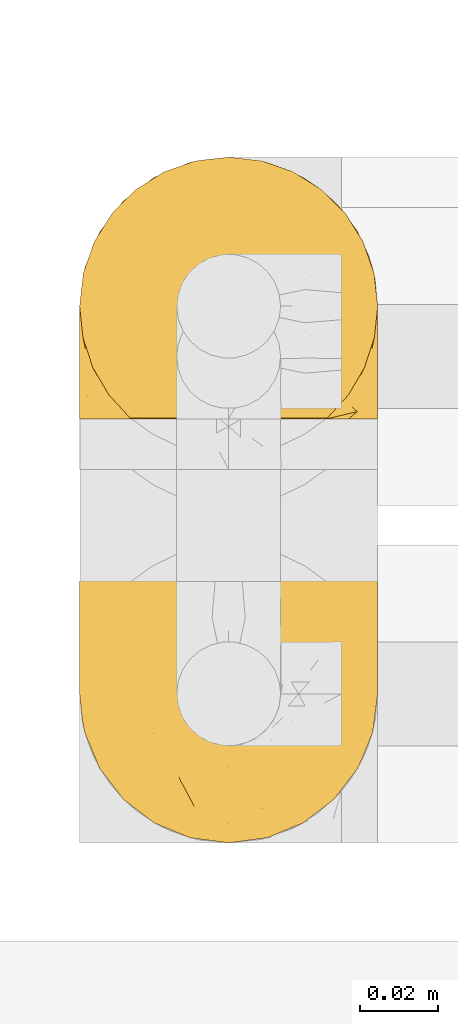
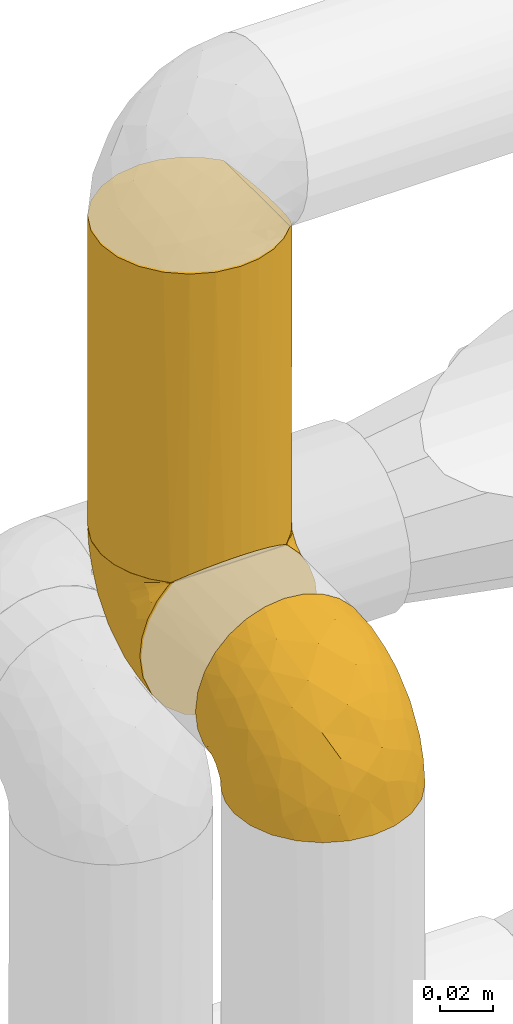
# One storey, part 328 of 827: 3 coverings.
"""IFC2X3 building model written with IfcOpenShell, lengths in millimetres."""

from ifc_helpers import new_model, entity, si_unit, converted_unit, derived_unit, direction, frame, origin, place, context, subcontext, project, spatial, faceted_brep, element, save


model = new_model("IFC2X3")

# Units and contexts
model_context = context("Model", 3, precision=0.01, world=origin(), true_north=direction((6.12303176911189e-17, 1.0)))
body_context = subcontext(model_context, "Body", "Model", "MODEL_VIEW")
ifc_project = project(units=[si_unit("LENGTHUNIT", "METRE", prefix="MILLI"), si_unit("AREAUNIT", "SQUARE_METRE"), si_unit("VOLUMEUNIT", "CUBIC_METRE"), converted_unit("PLANEANGLEUNIT", "DEGREE", entity("IfcRatioMeasure", 0.0174532925199433), si_unit("PLANEANGLEUNIT", "RADIAN"), dimensions=[0, 0, 0, 0, 0, 0, 0]), si_unit("MASSUNIT", "GRAM", prefix="KILO"), derived_unit("MASSDENSITYUNIT", [(si_unit("MASSUNIT", "GRAM", prefix="KILO"), 1), (si_unit("LENGTHUNIT", "METRE"), -3)]), derived_unit("MOMENTOFINERTIAUNIT", [(si_unit("LENGTHUNIT", "METRE"), 4)]), si_unit("TIMEUNIT", "SECOND"), si_unit("FREQUENCYUNIT", "HERTZ"), si_unit("THERMODYNAMICTEMPERATUREUNIT", "DEGREE_CELSIUS"), derived_unit("THERMALTRANSMITTANCEUNIT", [(si_unit("MASSUNIT", "GRAM", prefix="KILO"), 1), (si_unit("THERMODYNAMICTEMPERATUREUNIT", "KELVIN"), -1), (si_unit("TIMEUNIT", "SECOND"), -3)]), derived_unit("VOLUMETRICFLOWRATEUNIT", [(si_unit("LENGTHUNIT", "METRE"), 3), (si_unit("TIMEUNIT", "SECOND"), -1)]), derived_unit("MASSFLOWRATEUNIT", [(si_unit("MASSUNIT", "GRAM", prefix="KILO"), 1), (si_unit("TIMEUNIT", "SECOND"), -1)]), derived_unit("ROTATIONALFREQUENCYUNIT", [(si_unit("TIMEUNIT", "SECOND"), -1)]), si_unit("ELECTRICCURRENTUNIT", "AMPERE"), si_unit("ELECTRICVOLTAGEUNIT", "VOLT"), si_unit("POWERUNIT", "WATT"), si_unit("FORCEUNIT", "NEWTON", prefix="KILO"), si_unit("ILLUMINANCEUNIT", "LUX"), si_unit("LUMINOUSFLUXUNIT", "LUMEN"), si_unit("LUMINOUSINTENSITYUNIT", "CANDELA"), derived_unit("USERDEFINED", [(si_unit("MASSUNIT", "GRAM", prefix="KILO"), -1), (si_unit("LENGTHUNIT", "METRE"), -2), (si_unit("TIMEUNIT", "SECOND"), 3), (si_unit("LUMINOUSFLUXUNIT", "LUMEN"), 1)]), derived_unit("LINEARVELOCITYUNIT", [(si_unit("LENGTHUNIT", "METRE"), 1), (si_unit("TIMEUNIT", "SECOND"), -1)]), si_unit("PRESSUREUNIT", "PASCAL"), derived_unit("USERDEFINED", [(si_unit("LENGTHUNIT", "METRE"), -2), (si_unit("MASSUNIT", "GRAM", prefix="KILO"), 1), (si_unit("TIMEUNIT", "SECOND"), -2)]), derived_unit("LINEARFORCEUNIT", [(si_unit("MASSUNIT", "GRAM", prefix="KILO"), 1), (si_unit("LENGTHUNIT", "METRE"), 1), (si_unit("TIMEUNIT", "SECOND"), -2), (si_unit("LENGTHUNIT", "METRE"), -1)]), derived_unit("PLANARFORCEUNIT", [(si_unit("MASSUNIT", "GRAM", prefix="KILO"), 1), (si_unit("LENGTHUNIT", "METRE"), 1), (si_unit("TIMEUNIT", "SECOND"), -2), (si_unit("LENGTHUNIT", "METRE"), -2)])], contexts=[model_context])

# Site, building, storey
site_placement = place(None, origin())
site = spatial("IfcSite", under=ifc_project, at=site_placement, CompositionType="ELEMENT")
building_placement = place(site_placement, origin())
building = spatial("IfcBuilding", under=site, at=building_placement, CompositionType="ELEMENT")
storey_placement = place(building_placement, frame((0.0, 0.0, 28200.0)))
storey = spatial("IfcBuildingStorey", under=building, at=storey_placement, Name="08", CompositionType="ELEMENT", Elevation=28200.0)

# Coverings
covering_1_placement = place(storey_placement, frame((34485.34, 18294.87, 2769.3)))
element("IfcCovering", 1, at=covering_1_placement, inside=storey, Name=":ADSK_", ObjectType=":ADSK_", PredefinedType="INSULATION", context=body_context, shape_type="Brep", body=[
    faceted_brep([(5.41, 69.15, 47.38), (9.99, 69.15, 54.67), (16.08, 69.15, 60.76), (23.37, 69.15, 65.34), (31.49, 69.15, 68.18), (40.05, 69.15, 69.15), (48.61, 69.15, 68.18), (56.73, 69.15, 65.33), (64.02, 69.15, 60.75), (70.11, 69.15, 54.66), (74.69, 69.15, 47.37), (77.53, 69.15, 39.25), (78.5, 69.15, 30.7), (77.63, 69.15, 22.59), (75.08, 69.15, 14.86), (70.97, 69.15, 7.84), (65.47, 69.15, 1.85), (63.27, 69.15, 1.85), (61.53, 69.15, 1.85), (59.57, 69.15, 1.85), (57.6, 69.15, 1.85), (55.63, 69.15, 1.85), (53.67, 69.15, 1.85), (51.7, 69.15, 1.85), (49.73, 69.15, 1.85), (47.54, 69.15, 1.85), (45.34, 69.15, 1.85), (43.15, 69.15, 1.85), (40.96, 69.15, 1.85), (38.76, 69.15, 1.85), (36.57, 69.15, 1.85), (34.37, 69.15, 1.85), (32.18, 69.15, 1.85), (29.98, 69.15, 1.85), (27.79, 69.15, 1.85), (25.6, 69.15, 1.85), (23.4, 69.15, 1.85), (21.21, 69.15, 1.85), (19.01, 69.15, 1.85), (16.82, 69.15, 1.85), (14.62, 69.15, 1.85), (9.12, 69.15, 7.85), (5.0, 69.15, 14.88), (2.46, 69.15, 22.61), (1.6, 69.15, 30.7), (2.56, 69.15, 39.26), (65.47, 68.89, 1.6), (70.97, 62.89, 1.6), (75.09, 55.87, 1.6), (77.63, 48.14, 1.6), (78.5, 40.05, 1.6), (77.19, 30.09, 1.6), (73.34, 20.82, 1.6), (67.23, 12.86, 1.6), (59.27, 6.75, 1.6), (50.0, 2.91, 1.6), (40.05, 1.6, 1.6), (30.09, 2.91, 1.6), (20.82, 6.75, 1.6), (12.86, 12.86, 1.6), (6.75, 20.82, 1.6), (2.91, 30.09, 1.6), (1.6, 40.05, 1.6), (2.46, 48.14, 1.6), (5.0, 55.87, 1.6), (9.12, 62.89, 1.6), (14.62, 68.89, 1.6), (16.82, 68.89, 1.6), (17.8, 68.89, 1.6), (19.39, 68.89, 1.6), (20.98, 68.89, 1.6), (22.57, 68.89, 1.6), (24.16, 68.89, 1.6), (25.75, 68.89, 1.6), (27.33, 68.89, 1.6), (28.92, 68.89, 1.6), (30.51, 68.89, 1.6), (32.1, 68.89, 1.6), (33.69, 68.89, 1.6), (35.28, 68.89, 1.6), (36.87, 68.89, 1.6), (38.46, 68.89, 1.6), (40.05, 68.89, 1.6), (41.63, 68.89, 1.6), (43.22, 68.89, 1.6), (44.81, 68.89, 1.6), (46.4, 68.89, 1.6), (47.99, 68.89, 1.6), (49.58, 68.89, 1.6), (51.17, 68.89, 1.6), (52.76, 68.89, 1.6), (54.72, 68.89, 1.6), (56.69, 68.89, 1.6), (58.88, 68.89, 1.6), (61.08, 68.89, 1.6), (63.27, 68.89, 1.6), (37.77, 68.97, 1.78), (36.07, 68.96, 1.77), (32.96, 68.97, 1.78), (31.36, 68.97, 1.77), (56.52, 68.98, 1.79), (54.96, 68.97, 1.78), (18.75, 68.96, 1.76), (58.07, 68.96, 1.77), (50.37, 68.96, 1.77), (23.36, 68.96, 1.76), (24.95, 68.96, 1.77), (42.43, 68.96, 1.77), (15.97, 69.0, 1.8), (51.96, 68.96, 1.76), (53.47, 68.96, 1.77), (48.63, 68.97, 1.78), (63.93, 68.96, 1.77), (40.93, 68.96, 1.77), (29.72, 68.96, 1.76), (62.4, 68.97, 1.77), (60.92, 68.97, 1.78), (17.31, 68.97, 1.77), (21.74, 68.96, 1.77), (34.56, 68.96, 1.77), (20.18, 68.97, 1.78), (14.62, 68.97, 1.77), (14.62, 69.02, 1.8), (14.62, 69.08, 1.82), (65.47, 68.97, 1.77), (65.47, 68.94, 1.72), (65.47, 68.92, 1.66), (59.5, 68.96, 1.76), (47.1, 68.96, 1.77), (45.61, 68.95, 1.76), (28.18, 68.96, 1.77), (14.62, 68.92, 1.66), (14.62, 68.94, 1.72), (26.61, 68.98, 1.78), (65.47, 69.08, 1.82), (65.47, 69.02, 1.8), (39.32, 68.96, 1.77), (44.12, 68.97, 1.78), (72.26, 61.33, 3.72), (76.57, 53.1, 7.41), (71.77, 63.33, 6.13), (77.9, 55.53, 19.34), (76.56, 63.33, 17.64), (78.5, 54.6, 26.8), (78.5, 41.99, 8.87), (75.52, 57.07, 9.2), (76.13, 57.95, 12.79), (77.81, 51.56, 14.62), (78.5, 41.58, 7.34), (72.4, 61.7, 5.33), (71.77, 65.0, 7.7), (72.25, 67.02, 9.41), (78.5, 61.87, 28.75), (78.5, 49.27, 21.47), (78.5, 43.94, 16.15), (75.75, 61.21, 14.14), (78.5, 63.4, 29.16), (50.46, 33.11, 57.02), (52.75, 52.82, 64.92), (40.05, 43.3, 64.0), (77.7, 33.73, 11.92), (77.66, 36.52, 19.16), (71.02, 24.87, 28.65), (63.45, 14.17, 24.62), (70.55, 18.43, 15.19), (75.57, 28.67, 18.36), (75.57, 26.0, 9.2), (72.61, 49.25, 46.98), (72.61, 59.72, 50.24), (67.24, 55.1, 56.1), (77.74, 44.72, 28.97), (57.43, 34.15, 54.46), (47.19, 5.25, 21.34), (54.76, 6.75, 18.4), (40.05, 55.54, 66.44), (63.45, 10.47, 12.07), (60.1, 25.49, 45.49), (63.72, 35.53, 50.57), (76.83, 48.22, 36.04), (76.34, 58.71, 42.07), (60.51, 57.42, 62.12), (72.59, 34.84, 37.37), (76.05, 36.87, 29.39), (66.15, 45.01, 53.59), (60.51, 44.4, 58.06), (51.88, 23.96, 49.27), (55.34, 11.2, 29.63), (48.67, 10.56, 33.21), (53.89, 16.81, 40.1), (46.73, 17.38, 44.08), (40.05, 21.38, 49.36), (40.05, 32.34, 56.68), (40.05, 4.3, 15.2), (63.95, 20.65, 35.57), (67.24, 29.66, 41.7), (69.62, 39.6, 46.4), (73.6, 42.55, 41.41), (40.05, 6.74, 27.45), (40.05, 14.06, 38.4), (4.52, 26.84, 12.99), (32.72, 5.28, 21.33), (27.18, 18.52, 42.89), (29.63, 33.13, 57.04), (12.86, 55.1, 56.11), (19.59, 57.43, 62.13), (9.54, 20.72, 21.89), (16.64, 11.46, 16.62), (17.48, 17.69, 32.9), (7.49, 49.26, 46.99), (7.49, 59.73, 50.25), (3.75, 58.71, 42.08), (20.75, 29.72, 49.91), (2.33, 35.35, 15.6), (1.6, 43.94, 16.15), (1.6, 41.99, 8.87), (1.6, 63.4, 29.16), (26.94, 4.93, 13.16), (9.54, 17.46, 10.83), (31.21, 10.94, 33.8), (25.33, 8.92, 25.02), (27.35, 52.83, 64.92), (8.17, 29.34, 32.83), (4.3, 30.26, 20.56), (19.59, 44.4, 58.07), (2.23, 39.06, 21.46), (2.45, 43.06, 28.1), (1.6, 54.6, 26.8), (1.6, 49.27, 21.47), (12.86, 42.69, 51.29), (3.27, 48.2, 36.04), (1.6, 61.87, 28.75), (2.29, 33.44, 8.45), (12.86, 29.67, 41.73), (6.89, 38.5, 39.27), (12.43, 23.35, 33.56), (4.1, 34.97, 27.29), (3.53, 53.1, 7.41), (6.88, 59.68, 3.51), (8.16, 62.19, 4.68), (9.02, 64.11, 5.52), (5.0, 57.97, 8.75), (3.96, 57.95, 12.79), (3.52, 63.33, 17.65), (2.4, 51.77, 13.9), (7.83, 67.02, 9.42), (8.32, 64.98, 7.68), (2.19, 55.53, 19.33), (4.34, 61.22, 14.13)], [[[0, 1, 2, 3, 4, 5, 6, 7, 8, 9, 10, 11, 12, 13, 14, 15, 16, 17, 18, 19, 20, 21, 22, 23, 24, 25, 26, 27, 28, 29, 30, 31, 32, 33, 34, 35, 36, 37, 38, 39, 40, 41, 42, 43, 44, 45]], [[46, 47, 48, 49, 50, 51, 52, 53, 54, 55, 56, 57, 58, 59, 60, 61, 62, 63, 64, 65, 66, 67, 68, 69, 70, 71, 72, 73, 74, 75, 76, 77, 78, 79, 80, 81, 82, 83, 84, 85, 86, 87, 88, 89, 90, 91, 92, 93, 94, 95]], [[96, 97, 30]], [[98, 77, 99]], [[100, 101, 21]], [[69, 68, 102]], [[20, 19, 103]], [[24, 23, 104]], [[20, 103, 100]], [[72, 105, 106]], [[84, 83, 107]], [[89, 88, 104]], [[108, 67, 66]], [[109, 110, 90]], [[111, 25, 24]], [[112, 17, 16]], [[82, 113, 83]], [[109, 23, 22]], [[114, 76, 75]], [[105, 36, 106]], [[104, 111, 24]], [[18, 115, 116]], [[97, 96, 80]], [[67, 108, 117]], [[105, 71, 118]], [[31, 97, 119]], [[102, 120, 69]], [[108, 121, 122, 123, 40]], [[112, 95, 115]], [[17, 115, 18]], [[94, 116, 115]], [[117, 68, 67]], [[38, 117, 39]], [[112, 124, 125, 126, 46]], [[17, 112, 115]], [[70, 120, 118]], [[39, 117, 108]], [[120, 38, 37]], [[120, 37, 118]], [[120, 70, 69]], [[116, 94, 127]], [[128, 86, 129]], [[117, 38, 102]], [[74, 130, 75]], [[99, 33, 32]], [[115, 95, 94]], [[39, 108, 40]], [[108, 66, 131, 132, 121]], [[105, 72, 71]], [[118, 37, 36]], [[71, 70, 118]], [[35, 106, 36]], [[36, 105, 118]], [[35, 133, 106]], [[74, 73, 133]], [[106, 133, 73]], [[99, 114, 33]], [[133, 35, 34]], [[73, 72, 106]], [[95, 112, 46]], [[112, 16, 134, 135, 124]], [[130, 114, 75]], [[99, 76, 114]], [[114, 130, 33]], [[34, 33, 130]], [[78, 77, 98]], [[98, 119, 78]], [[130, 133, 34]], [[133, 130, 74]], [[79, 97, 80]], [[98, 99, 32]], [[98, 32, 31]], [[77, 76, 99]], [[97, 79, 119]], [[136, 96, 29]], [[30, 97, 31]], [[136, 29, 28]], [[81, 80, 96]], [[29, 96, 30]], [[31, 119, 98]], [[119, 79, 78]], [[96, 136, 81]], [[82, 81, 136]], [[113, 107, 83]], [[84, 107, 137]], [[107, 27, 137]], [[113, 28, 107]], [[27, 107, 28]], [[85, 84, 137]], [[137, 27, 26]], [[113, 136, 28]], [[136, 113, 82]], [[109, 89, 104]], [[86, 85, 129]], [[89, 109, 90]], [[111, 87, 128]], [[26, 129, 137]], [[88, 111, 104]], [[25, 111, 128]], [[22, 110, 109]], [[23, 109, 104]], [[110, 91, 90]], [[100, 92, 101]], [[110, 22, 101]], [[91, 110, 101]], [[116, 19, 18]], [[111, 88, 87]], [[127, 103, 19]], [[25, 128, 26]], [[86, 128, 87]], [[128, 129, 26]], [[137, 129, 85]], [[120, 102, 38]], [[117, 102, 68]], [[91, 101, 92]], [[21, 101, 22]], [[93, 92, 103]], [[100, 21, 20]], [[100, 103, 92]], [[127, 93, 103]], [[93, 127, 94]], [[116, 127, 19]], [[126, 138, 47]], [[48, 138, 139]], [[140, 125, 124]], [[141, 142, 143]], [[144, 49, 139]], [[145, 140, 146]], [[48, 139, 49]], [[139, 145, 147]], [[49, 144, 148, 50]], [[126, 125, 149]], [[14, 13, 142]], [[150, 146, 140]], [[149, 140, 145]], [[151, 150, 135]], [[151, 14, 142]], [[16, 15, 134]], [[13, 152, 142]], [[124, 150, 140]], [[141, 143, 153]], [[14, 151, 15]], [[15, 151, 134]], [[47, 46, 126]], [[139, 154, 144]], [[138, 48, 47]], [[125, 140, 149]], [[135, 134, 151]], [[146, 155, 141]], [[145, 146, 147]], [[149, 139, 138]], [[147, 153, 154]], [[147, 146, 141]], [[139, 147, 154]], [[139, 149, 145]], [[149, 138, 126]], [[147, 141, 153]], [[146, 150, 155]], [[151, 155, 150]], [[142, 141, 155]], [[13, 12, 156, 152]], [[152, 143, 142]], [[151, 142, 155]], [[150, 124, 135]], [[157, 158, 159]], [[160, 154, 161]], [[162, 163, 164]], [[165, 166, 160]], [[167, 168, 169]], [[153, 170, 161]], [[156, 12, 11]], [[158, 157, 171]], [[172, 55, 173]], [[158, 6, 174]], [[175, 54, 53]], [[52, 166, 164]], [[52, 164, 53]], [[54, 175, 173]], [[166, 52, 51]], [[176, 177, 171]], [[178, 143, 179]], [[156, 11, 179]], [[8, 7, 180]], [[169, 9, 8]], [[179, 143, 152, 156]], [[179, 11, 10]], [[168, 179, 10]], [[181, 162, 182]], [[179, 167, 178]], [[183, 184, 177]], [[183, 169, 184]], [[176, 171, 185]], [[172, 186, 187]], [[158, 7, 6]], [[159, 158, 174]], [[184, 180, 158]], [[54, 173, 55]], [[180, 169, 8]], [[188, 189, 187]], [[9, 168, 10]], [[186, 188, 187]], [[190, 157, 159, 191]], [[55, 172, 192]], [[176, 193, 194]], [[161, 170, 182]], [[162, 164, 165]], [[175, 164, 163]], [[51, 50, 148]], [[167, 195, 196]], [[178, 182, 170]], [[6, 5, 174]], [[158, 180, 7]], [[169, 180, 184]], [[169, 168, 9]], [[179, 168, 167]], [[182, 162, 165]], [[162, 194, 193]], [[161, 165, 160]], [[195, 181, 196]], [[192, 172, 197]], [[192, 56, 55]], [[189, 190, 198]], [[198, 197, 187]], [[172, 187, 197]], [[185, 189, 188]], [[198, 187, 189]], [[186, 172, 173]], [[173, 163, 186]], [[193, 186, 163]], [[176, 185, 188]], [[185, 157, 190]], [[188, 186, 193]], [[177, 176, 194]], [[188, 193, 176]], [[162, 193, 163]], [[195, 177, 194]], [[171, 177, 184]], [[181, 195, 194]], [[183, 167, 169]], [[162, 181, 194]], [[196, 182, 178]], [[158, 171, 184]], [[171, 157, 185]], [[177, 195, 183]], [[167, 183, 195]], [[182, 196, 181]], [[178, 170, 143]], [[178, 167, 196]], [[164, 175, 53]], [[173, 175, 163]], [[160, 51, 148]], [[164, 166, 165]], [[51, 160, 166]], [[160, 148, 144, 154]], [[153, 161, 154]], [[182, 165, 161]], [[190, 189, 185]], [[143, 170, 153]], [[60, 199, 61]], [[197, 200, 192]], [[201, 190, 202]], [[200, 57, 192]], [[203, 204, 2]], [[205, 206, 207]], [[208, 209, 210]], [[211, 207, 201]], [[212, 213, 214]], [[45, 215, 210]], [[216, 206, 58]], [[45, 44, 215]], [[59, 217, 60]], [[60, 217, 199]], [[0, 45, 210]], [[218, 201, 219]], [[202, 159, 220]], [[205, 221, 222]], [[223, 204, 203]], [[1, 203, 2]], [[57, 200, 216]], [[220, 3, 204]], [[220, 174, 4]], [[1, 0, 209]], [[212, 224, 213]], [[225, 226, 227]], [[228, 223, 203]], [[208, 210, 229]], [[210, 226, 229]], [[3, 220, 4]], [[58, 206, 59]], [[209, 203, 1]], [[202, 220, 223]], [[228, 203, 208]], [[202, 211, 201]], [[3, 2, 204]], [[202, 190, 191, 159]], [[210, 215, 230, 226]], [[199, 212, 231]], [[232, 233, 221]], [[233, 208, 229]], [[207, 206, 219]], [[217, 206, 205]], [[227, 224, 225]], [[233, 232, 228]], [[201, 207, 219]], [[234, 232, 221]], [[218, 219, 200]], [[202, 223, 211]], [[174, 220, 159]], [[174, 5, 4]], [[61, 231, 62]], [[220, 204, 223]], [[210, 209, 0]], [[203, 209, 208]], [[225, 233, 229]], [[224, 227, 213]], [[221, 233, 235]], [[57, 56, 192]], [[198, 218, 197]], [[200, 219, 216]], [[201, 198, 190]], [[197, 218, 200]], [[198, 201, 218]], [[206, 216, 219]], [[58, 57, 216]], [[231, 212, 214]], [[222, 212, 199]], [[228, 211, 223]], [[207, 211, 232]], [[62, 231, 214]], [[199, 231, 61]], [[233, 228, 208]], [[211, 228, 232]], [[222, 221, 235]], [[234, 205, 207]], [[206, 217, 59]], [[199, 217, 205]], [[205, 222, 199]], [[224, 222, 235]], [[222, 224, 212]], [[224, 235, 225]], [[233, 225, 235]], [[226, 225, 229]], [[205, 234, 221]], [[207, 232, 234]], [[63, 214, 236]], [[214, 213, 236]], [[214, 63, 62]], [[237, 236, 238]], [[238, 132, 131]], [[236, 237, 64]], [[239, 240, 241]], [[63, 236, 64]], [[131, 66, 65]], [[237, 131, 65]], [[242, 230, 43]], [[237, 65, 64]], [[239, 121, 132]], [[42, 242, 43]], [[241, 240, 243]], [[41, 123, 244]], [[43, 230, 215, 44]], [[244, 122, 245]], [[227, 246, 243]], [[241, 247, 245]], [[121, 239, 245]], [[41, 40, 123]], [[132, 238, 239]], [[244, 42, 41]], [[131, 237, 238]], [[240, 239, 238]], [[245, 239, 241]], [[247, 241, 246]], [[247, 244, 245]], [[238, 236, 240]], [[243, 236, 213]], [[236, 243, 240]], [[227, 226, 246]], [[243, 213, 227]], [[242, 246, 226]], [[243, 246, 241]], [[246, 242, 247]], [[244, 247, 242]], [[242, 226, 230]], [[42, 244, 242]], [[122, 244, 123]], [[122, 121, 245]]]),
])
covering_2_placement = place(storey_placement, frame((34485.39, 18394.91, 2827.5)))
element("IfcCovering", 2, at=covering_2_placement, inside=storey, Name=":ADSK_", ObjectType=":ADSK_", PredefinedType="INSULATION", context=body_context, shape_type="Brep", body=[
    faceted_brep([(2.48, 31.79, 1.6), (1.6, 40.0, 1.6), (2.9, 49.93, 1.6), (6.74, 59.2, 1.6), (12.84, 67.15, 1.6), (20.8, 73.25, 1.6), (30.06, 77.09, 1.6), (40.0, 78.4, 1.6), (49.93, 77.09, 1.6), (59.2, 73.25, 1.6), (67.15, 67.15, 1.6), (73.25, 59.2, 1.6), (77.09, 49.93, 1.6), (78.4, 40.0, 1.6), (77.51, 31.79, 1.6), (74.9, 23.98, 1.6), (70.68, 16.91, 1.6), (65.05, 10.9, 1.6), (14.94, 10.9, 1.6), (9.31, 16.91, 1.6), (5.09, 23.98, 1.6), (1.6, 40.0, 143.56), (2.9, 30.06, 143.56), (6.74, 20.8, 143.56), (12.84, 12.84, 143.56), (20.8, 6.74, 143.56), (30.06, 2.9, 143.56), (40.0, 1.6, 143.56), (48.2, 2.48, 143.56), (56.01, 5.09, 143.56), (63.08, 9.31, 143.56), (69.1, 14.94, 143.56), (69.1, 65.05, 143.56), (63.08, 70.68, 143.56), (56.01, 74.9, 143.56), (48.2, 77.51, 143.56), (40.0, 78.4, 143.56), (30.06, 77.09, 143.56), (20.8, 73.25, 143.56), (12.84, 67.15, 143.56), (6.74, 59.2, 143.56), (2.9, 49.93, 143.56), (73.07, 59.51, 139.59), (76.0, 53.36, 136.66), (77.79, 46.78, 134.87), (78.4, 40.0, 134.26), (77.79, 33.21, 134.87), (76.0, 26.63, 136.66), (73.07, 20.48, 139.59), (59.51, 6.92, 5.57), (53.36, 4.0, 8.5), (46.78, 2.2, 10.29), (40.0, 1.6, 10.9), (33.21, 2.2, 10.29), (26.63, 4.0, 8.5), (20.48, 6.92, 5.57)], [[[0, 1, 2, 3, 4, 5, 6, 7, 8, 9, 10, 11, 12, 13, 14, 15, 16, 17, 18, 19, 20]], [[21, 22, 23, 24, 25, 26, 27, 28, 29, 30, 31, 32, 33, 34, 35, 36, 37, 38, 39, 40, 41]], [[36, 35, 7]], [[34, 33, 9]], [[35, 34, 8]], [[8, 7, 35]], [[9, 8, 34]], [[33, 10, 9]], [[33, 32, 10]], [[32, 42, 11]], [[43, 44, 12]], [[42, 43, 11]], [[11, 43, 12]], [[13, 12, 44]], [[45, 13, 44]], [[32, 11, 10]], [[46, 47, 14]], [[48, 31, 16]], [[47, 48, 15]], [[45, 46, 13]], [[14, 13, 46]], [[47, 15, 14]], [[48, 16, 15]], [[31, 17, 16]], [[49, 30, 29]], [[50, 29, 28]], [[51, 28, 27]], [[49, 17, 30]], [[51, 50, 28]], [[52, 51, 27]], [[49, 29, 50]], [[30, 17, 31]], [[53, 52, 27]], [[53, 27, 26]], [[54, 26, 25]], [[54, 53, 26]], [[18, 55, 25]], [[54, 25, 55]], [[25, 24, 18]], [[19, 24, 23]], [[20, 23, 22]], [[0, 22, 21]], [[19, 23, 20]], [[20, 22, 0]], [[21, 1, 0]], [[24, 19, 18]], [[2, 1, 21, 41]], [[3, 2, 41, 40]], [[40, 39, 4, 3]], [[6, 5, 38, 37]], [[7, 6, 37, 36]], [[39, 38, 5, 4]], [[49, 50, 51, 52, 53, 54, 55, 18, 17]], [[31, 48, 47, 46, 45, 44, 43, 42, 32]]]),
])
covering_3_placement = place(storey_placement, frame((34485.34, 18404.21, 2759.95)))
element("IfcCovering", 3, at=covering_3_placement, inside=storey, Name=":ADSK_", ObjectType=":ADSK_", PredefinedType="INSULATION", context=body_context, shape_type="Brep", body=[
    faceted_brep([(74.68, 47.38, 69.15), (70.1, 54.67, 69.15), (64.01, 60.76, 69.15), (56.72, 65.34, 69.15), (48.6, 68.18, 69.15), (40.05, 69.15, 69.15), (31.49, 68.18, 69.15), (23.36, 65.33, 69.15), (16.07, 60.75, 69.15), (9.98, 54.66, 69.15), (5.4, 47.37, 69.15), (2.56, 39.25, 69.15), (1.6, 30.7, 69.15), (2.46, 22.59, 69.15), (5.01, 14.86, 69.15), (9.13, 7.84, 69.15), (14.62, 1.85, 69.15), (16.82, 1.85, 69.15), (18.56, 1.85, 69.15), (20.52, 1.85, 69.15), (22.49, 1.85, 69.15), (24.46, 1.85, 69.15), (26.42, 1.85, 69.15), (28.39, 1.85, 69.15), (30.36, 1.85, 69.15), (32.55, 1.85, 69.15), (34.75, 1.85, 69.15), (36.94, 1.85, 69.15), (39.13, 1.85, 69.15), (41.33, 1.85, 69.15), (43.52, 1.85, 69.15), (45.72, 1.85, 69.15), (47.91, 1.85, 69.15), (50.11, 1.85, 69.15), (52.3, 1.85, 69.15), (54.49, 1.85, 69.15), (56.69, 1.85, 69.15), (58.88, 1.85, 69.15), (61.08, 1.85, 69.15), (63.27, 1.85, 69.15), (65.47, 1.85, 69.15), (70.97, 7.85, 69.15), (75.09, 14.88, 69.15), (77.64, 22.61, 69.15), (78.5, 30.7, 69.15), (77.53, 39.26, 69.15), (14.62, 1.6, 68.89), (9.12, 1.6, 62.89), (5.0, 1.6, 55.87), (2.46, 1.6, 48.14), (1.6, 1.6, 40.05), (2.91, 1.6, 30.09), (6.75, 1.6, 20.82), (12.86, 1.6, 12.86), (20.82, 1.6, 6.75), (30.09, 1.6, 2.91), (40.05, 1.6, 1.6), (50.0, 1.6, 2.91), (59.27, 1.6, 6.75), (67.23, 1.6, 12.86), (73.34, 1.6, 20.82), (77.19, 1.6, 30.09), (78.5, 1.6, 40.05), (77.63, 1.6, 48.14), (75.09, 1.6, 55.87), (70.97, 1.6, 62.89), (65.47, 1.6, 68.89), (63.27, 1.6, 68.89), (62.29, 1.6, 68.89), (60.7, 1.6, 68.89), (59.11, 1.6, 68.89), (57.52, 1.6, 68.89), (55.93, 1.6, 68.89), (54.34, 1.6, 68.89), (52.76, 1.6, 68.89), (51.17, 1.6, 68.89), (49.58, 1.6, 68.89), (47.99, 1.6, 68.89), (46.4, 1.6, 68.89), (44.81, 1.6, 68.89), (43.22, 1.6, 68.89), (41.63, 1.6, 68.89), (40.05, 1.6, 68.89), (38.46, 1.6, 68.89), (36.87, 1.6, 68.89), (35.28, 1.6, 68.89), (33.69, 1.6, 68.89), (32.1, 1.6, 68.89), (30.51, 1.6, 68.89), (28.92, 1.6, 68.89), (27.33, 1.6, 68.89), (25.37, 1.6, 68.89), (23.4, 1.6, 68.89), (21.21, 1.6, 68.89), (19.01, 1.6, 68.89), (16.82, 1.6, 68.89), (42.32, 1.78, 68.97), (44.02, 1.77, 68.96), (47.13, 1.78, 68.97), (48.74, 1.77, 68.97), (23.57, 1.79, 68.98), (25.13, 1.78, 68.97), (61.34, 1.76, 68.96), (22.02, 1.77, 68.96), (29.72, 1.77, 68.96), (56.73, 1.76, 68.96), (55.14, 1.77, 68.96), (37.66, 1.77, 68.96), (64.12, 1.8, 69.0), (28.13, 1.76, 68.96), (26.62, 1.77, 68.96), (31.46, 1.78, 68.97), (16.16, 1.77, 68.96), (39.16, 1.77, 68.96), (50.37, 1.76, 68.96), (17.69, 1.77, 68.97), (19.17, 1.78, 68.97), (62.78, 1.77, 68.97), (58.35, 1.77, 68.96), (45.53, 1.77, 68.96), (59.91, 1.78, 68.97), (65.47, 1.77, 68.97), (65.47, 1.8, 69.02), (65.47, 1.82, 69.08), (14.62, 1.77, 68.97), (14.62, 1.72, 68.94), (14.62, 1.66, 68.92), (20.59, 1.76, 68.96), (32.99, 1.77, 68.96), (34.48, 1.76, 68.95), (51.91, 1.77, 68.96), (65.47, 1.66, 68.92), (65.47, 1.72, 68.94), (53.48, 1.78, 68.98), (14.62, 1.82, 69.08), (14.62, 1.8, 69.02), (40.77, 1.77, 68.96), (35.97, 1.78, 68.97), (7.84, 3.72, 61.33), (3.53, 7.41, 53.1), (8.32, 6.13, 63.33), (1.6, 21.47, 49.27), (2.19, 19.34, 55.53), (1.6, 26.8, 54.6), (1.6, 8.87, 41.99), (4.57, 9.2, 57.07), (3.96, 12.79, 57.95), (2.28, 14.62, 51.56), (1.6, 7.34, 41.58), (7.69, 5.33, 61.7), (3.53, 17.64, 63.33), (8.32, 7.7, 65.0), (7.84, 9.41, 67.02), (1.6, 28.75, 61.87), (1.6, 16.15, 43.94), (4.34, 14.14, 61.21), (1.6, 29.16, 63.4), (29.63, 57.02, 33.11), (27.34, 64.92, 52.82), (40.05, 64.0, 43.3), (2.39, 11.92, 33.73), (2.43, 19.16, 36.52), (9.07, 28.65, 24.87), (16.64, 24.62, 14.17), (9.54, 15.19, 18.43), (4.52, 18.36, 28.67), (4.52, 9.2, 26.0), (7.49, 46.98, 49.25), (7.49, 50.24, 59.72), (12.85, 56.1, 55.1), (2.35, 28.97, 44.72), (22.66, 54.46, 34.15), (32.9, 21.34, 5.25), (25.33, 18.4, 6.75), (40.05, 66.44, 55.54), (16.64, 12.07, 10.47), (19.99, 45.49, 25.49), (16.37, 50.57, 35.53), (3.26, 36.04, 48.22), (3.75, 42.07, 58.71), (19.58, 62.12, 57.42), (7.5, 37.37, 34.84), (4.04, 29.39, 36.87), (13.94, 53.59, 45.01), (19.58, 58.06, 44.4), (28.21, 49.27, 23.96), (24.75, 29.63, 11.2), (31.42, 33.21, 10.56), (26.2, 40.1, 16.81), (33.36, 44.08, 17.38), (40.05, 49.36, 21.38), (40.05, 56.68, 32.34), (40.05, 15.2, 4.3), (16.14, 35.57, 20.65), (12.85, 41.7, 29.66), (10.47, 46.4, 39.6), (6.49, 41.41, 42.55), (40.05, 27.45, 6.74), (40.05, 38.4, 14.06), (75.57, 12.99, 26.84), (47.37, 21.33, 5.28), (52.91, 42.89, 18.52), (50.46, 57.04, 33.13), (67.23, 56.11, 55.1), (60.5, 62.13, 57.43), (70.55, 21.89, 20.72), (63.45, 16.62, 11.46), (62.61, 32.9, 17.69), (72.6, 46.99, 49.26), (72.6, 50.25, 59.73), (76.34, 42.08, 58.71), (59.34, 49.91, 29.72), (77.76, 15.6, 35.35), (78.5, 16.15, 43.94), (78.5, 8.87, 41.99), (78.5, 29.16, 63.4), (53.16, 13.16, 4.93), (70.55, 10.83, 17.46), (48.88, 33.8, 10.94), (54.76, 25.02, 8.92), (52.74, 64.92, 52.83), (71.93, 32.83, 29.34), (75.79, 20.56, 30.26), (60.5, 58.07, 44.4), (77.86, 21.46, 39.06), (77.64, 28.1, 43.06), (78.5, 26.8, 54.6), (78.5, 21.47, 49.27), (67.23, 51.29, 42.69), (76.82, 36.04, 48.2), (78.5, 28.75, 61.87), (77.8, 8.45, 33.44), (67.23, 41.73, 29.67), (73.2, 39.27, 38.5), (67.66, 33.56, 23.35), (75.99, 27.29, 34.97), (76.57, 7.41, 53.1), (73.21, 3.51, 59.68), (71.93, 4.68, 62.19), (71.07, 5.52, 64.11), (75.09, 8.75, 57.97), (76.13, 12.79, 57.95), (76.57, 17.65, 63.33), (77.69, 13.9, 51.77), (72.26, 9.42, 67.02), (71.77, 7.68, 64.98), (77.9, 19.33, 55.53), (75.75, 14.13, 61.22)], [[[0, 1, 2, 3, 4, 5, 6, 7, 8, 9, 10, 11, 12, 13, 14, 15, 16, 17, 18, 19, 20, 21, 22, 23, 24, 25, 26, 27, 28, 29, 30, 31, 32, 33, 34, 35, 36, 37, 38, 39, 40, 41, 42, 43, 44, 45]], [[46, 47, 48, 49, 50, 51, 52, 53, 54, 55, 56, 57, 58, 59, 60, 61, 62, 63, 64, 65, 66, 67, 68, 69, 70, 71, 72, 73, 74, 75, 76, 77, 78, 79, 80, 81, 82, 83, 84, 85, 86, 87, 88, 89, 90, 91, 92, 93, 94, 95]], [[96, 97, 30]], [[98, 77, 99]], [[100, 101, 21]], [[69, 68, 102]], [[20, 19, 103]], [[24, 23, 104]], [[20, 103, 100]], [[72, 105, 106]], [[84, 83, 107]], [[89, 88, 104]], [[108, 67, 66]], [[109, 110, 90]], [[111, 25, 24]], [[112, 17, 16]], [[82, 113, 83]], [[109, 23, 22]], [[114, 76, 75]], [[105, 36, 106]], [[104, 111, 24]], [[18, 115, 116]], [[97, 96, 80]], [[67, 108, 117]], [[105, 71, 118]], [[31, 97, 119]], [[102, 120, 69]], [[108, 121, 122, 123, 40]], [[112, 95, 115]], [[17, 115, 18]], [[94, 116, 115]], [[117, 68, 67]], [[38, 117, 39]], [[112, 124, 125, 126, 46]], [[17, 112, 115]], [[70, 120, 118]], [[39, 117, 108]], [[120, 38, 37]], [[120, 37, 118]], [[120, 70, 69]], [[116, 94, 127]], [[128, 86, 129]], [[117, 38, 102]], [[74, 130, 75]], [[99, 33, 32]], [[115, 95, 94]], [[39, 108, 40]], [[108, 66, 131, 132, 121]], [[105, 72, 71]], [[118, 37, 36]], [[71, 70, 118]], [[35, 106, 36]], [[36, 105, 118]], [[35, 133, 106]], [[74, 73, 133]], [[106, 133, 73]], [[99, 114, 33]], [[133, 35, 34]], [[73, 72, 106]], [[95, 112, 46]], [[112, 16, 134, 135, 124]], [[130, 114, 75]], [[99, 76, 114]], [[114, 130, 33]], [[34, 33, 130]], [[78, 77, 98]], [[98, 119, 78]], [[130, 133, 34]], [[133, 130, 74]], [[79, 97, 80]], [[98, 99, 32]], [[98, 32, 31]], [[77, 76, 99]], [[97, 79, 119]], [[136, 96, 29]], [[30, 97, 31]], [[136, 29, 28]], [[81, 80, 96]], [[29, 96, 30]], [[31, 119, 98]], [[119, 79, 78]], [[96, 136, 81]], [[82, 81, 136]], [[113, 107, 83]], [[84, 107, 137]], [[107, 27, 137]], [[113, 28, 107]], [[27, 107, 28]], [[85, 84, 137]], [[137, 27, 26]], [[113, 136, 28]], [[136, 113, 82]], [[109, 89, 104]], [[86, 85, 129]], [[89, 109, 90]], [[111, 87, 128]], [[26, 129, 137]], [[88, 111, 104]], [[25, 111, 128]], [[22, 110, 109]], [[23, 109, 104]], [[110, 91, 90]], [[100, 92, 101]], [[110, 22, 101]], [[91, 110, 101]], [[116, 19, 18]], [[111, 88, 87]], [[127, 103, 19]], [[25, 128, 26]], [[86, 128, 87]], [[128, 129, 26]], [[137, 129, 85]], [[120, 102, 38]], [[117, 102, 68]], [[91, 101, 92]], [[21, 101, 22]], [[93, 92, 103]], [[100, 21, 20]], [[100, 103, 92]], [[127, 93, 103]], [[93, 127, 94]], [[116, 127, 19]], [[126, 138, 47]], [[48, 138, 139]], [[140, 125, 124]], [[141, 142, 143]], [[144, 49, 139]], [[145, 140, 146]], [[48, 139, 49]], [[139, 145, 147]], [[49, 144, 148, 50]], [[126, 125, 149]], [[14, 13, 150]], [[151, 146, 140]], [[149, 140, 145]], [[152, 151, 135]], [[152, 14, 150]], [[16, 15, 134]], [[13, 153, 150]], [[124, 151, 140]], [[141, 147, 142]], [[14, 152, 15]], [[15, 152, 134]], [[47, 46, 126]], [[139, 154, 144]], [[138, 48, 47]], [[125, 140, 149]], [[135, 134, 152]], [[146, 155, 142]], [[145, 146, 147]], [[149, 139, 138]], [[147, 141, 154]], [[147, 146, 142]], [[139, 147, 154]], [[139, 149, 145]], [[149, 138, 126]], [[155, 146, 151]], [[150, 143, 142]], [[152, 155, 151]], [[150, 142, 155]], [[13, 12, 156, 153]], [[153, 143, 150]], [[152, 150, 155]], [[151, 124, 135]], [[157, 158, 159]], [[160, 154, 161]], [[162, 163, 164]], [[165, 166, 160]], [[167, 168, 169]], [[141, 170, 161]], [[156, 12, 11]], [[158, 157, 171]], [[172, 55, 173]], [[158, 6, 174]], [[175, 54, 53]], [[52, 166, 164]], [[52, 164, 53]], [[54, 175, 173]], [[166, 52, 51]], [[176, 177, 171]], [[178, 143, 179]], [[156, 11, 179]], [[8, 7, 180]], [[169, 9, 8]], [[179, 143, 153, 156]], [[179, 11, 10]], [[168, 179, 10]], [[181, 162, 182]], [[179, 167, 178]], [[183, 184, 177]], [[183, 169, 184]], [[176, 171, 185]], [[172, 186, 187]], [[158, 7, 6]], [[159, 158, 174]], [[184, 180, 158]], [[54, 173, 55]], [[180, 169, 8]], [[188, 189, 187]], [[9, 168, 10]], [[186, 188, 187]], [[190, 157, 159, 191]], [[55, 172, 192]], [[176, 193, 194]], [[161, 170, 182]], [[162, 164, 165]], [[175, 164, 163]], [[51, 50, 148]], [[167, 195, 196]], [[178, 182, 170]], [[6, 5, 174]], [[158, 180, 7]], [[169, 180, 184]], [[169, 168, 9]], [[179, 168, 167]], [[182, 162, 165]], [[162, 194, 193]], [[161, 165, 160]], [[195, 181, 196]], [[192, 172, 197]], [[192, 56, 55]], [[189, 190, 198]], [[198, 197, 187]], [[172, 187, 197]], [[185, 189, 188]], [[198, 187, 189]], [[186, 172, 173]], [[173, 163, 186]], [[193, 186, 163]], [[176, 185, 188]], [[185, 157, 190]], [[188, 186, 193]], [[177, 176, 194]], [[188, 193, 176]], [[162, 193, 163]], [[195, 177, 194]], [[171, 177, 184]], [[181, 195, 194]], [[183, 167, 169]], [[162, 181, 194]], [[196, 182, 178]], [[158, 171, 184]], [[171, 157, 185]], [[177, 195, 183]], [[167, 183, 195]], [[182, 196, 181]], [[178, 170, 143]], [[178, 167, 196]], [[164, 175, 53]], [[173, 175, 163]], [[160, 51, 148]], [[164, 166, 165]], [[51, 160, 166]], [[160, 148, 144, 154]], [[141, 161, 154]], [[182, 165, 161]], [[190, 189, 185]], [[143, 170, 141]], [[60, 199, 61]], [[197, 200, 192]], [[201, 190, 202]], [[200, 57, 192]], [[203, 204, 2]], [[205, 206, 207]], [[208, 209, 210]], [[211, 207, 201]], [[212, 213, 214]], [[45, 215, 210]], [[216, 206, 58]], [[45, 44, 215]], [[59, 217, 60]], [[60, 217, 199]], [[0, 45, 210]], [[218, 201, 219]], [[202, 159, 220]], [[205, 221, 222]], [[223, 204, 203]], [[1, 203, 2]], [[57, 200, 216]], [[220, 3, 204]], [[220, 174, 4]], [[1, 0, 209]], [[212, 224, 213]], [[225, 226, 227]], [[228, 223, 203]], [[208, 210, 229]], [[210, 226, 229]], [[3, 220, 4]], [[58, 206, 59]], [[209, 203, 1]], [[202, 220, 223]], [[228, 203, 208]], [[202, 211, 201]], [[3, 2, 204]], [[202, 190, 191, 159]], [[210, 215, 230, 226]], [[199, 212, 231]], [[232, 233, 221]], [[233, 208, 229]], [[207, 206, 219]], [[217, 206, 205]], [[227, 224, 225]], [[233, 232, 228]], [[201, 207, 219]], [[234, 232, 221]], [[218, 219, 200]], [[202, 223, 211]], [[174, 220, 159]], [[174, 5, 4]], [[61, 231, 62]], [[220, 204, 223]], [[210, 209, 0]], [[203, 209, 208]], [[225, 233, 229]], [[224, 227, 213]], [[221, 233, 235]], [[57, 56, 192]], [[198, 218, 197]], [[200, 219, 216]], [[201, 198, 190]], [[197, 218, 200]], [[198, 201, 218]], [[206, 216, 219]], [[58, 57, 216]], [[231, 212, 214]], [[222, 212, 199]], [[228, 211, 223]], [[207, 211, 232]], [[62, 231, 214]], [[199, 231, 61]], [[233, 228, 208]], [[211, 228, 232]], [[222, 221, 235]], [[234, 205, 207]], [[206, 217, 59]], [[199, 217, 205]], [[205, 222, 199]], [[224, 222, 235]], [[222, 224, 212]], [[224, 235, 225]], [[233, 225, 235]], [[226, 225, 229]], [[205, 234, 221]], [[207, 232, 234]], [[63, 214, 236]], [[214, 213, 236]], [[214, 63, 62]], [[237, 236, 238]], [[238, 132, 131]], [[236, 237, 64]], [[239, 240, 241]], [[63, 236, 64]], [[131, 66, 65]], [[237, 131, 65]], [[242, 230, 43]], [[237, 65, 64]], [[239, 121, 132]], [[42, 242, 43]], [[241, 240, 243]], [[41, 123, 244]], [[43, 230, 215, 44]], [[244, 122, 245]], [[227, 246, 243]], [[241, 247, 245]], [[121, 239, 245]], [[41, 40, 123]], [[132, 238, 239]], [[244, 42, 41]], [[131, 237, 238]], [[240, 239, 238]], [[245, 239, 241]], [[247, 241, 246]], [[247, 244, 245]], [[238, 236, 240]], [[243, 236, 213]], [[236, 243, 240]], [[227, 226, 246]], [[243, 213, 227]], [[242, 246, 226]], [[243, 246, 241]], [[246, 242, 247]], [[244, 247, 242]], [[242, 226, 230]], [[42, 244, 242]], [[122, 244, 123]], [[122, 121, 245]]]),
])

save(model, "model.ifc")
